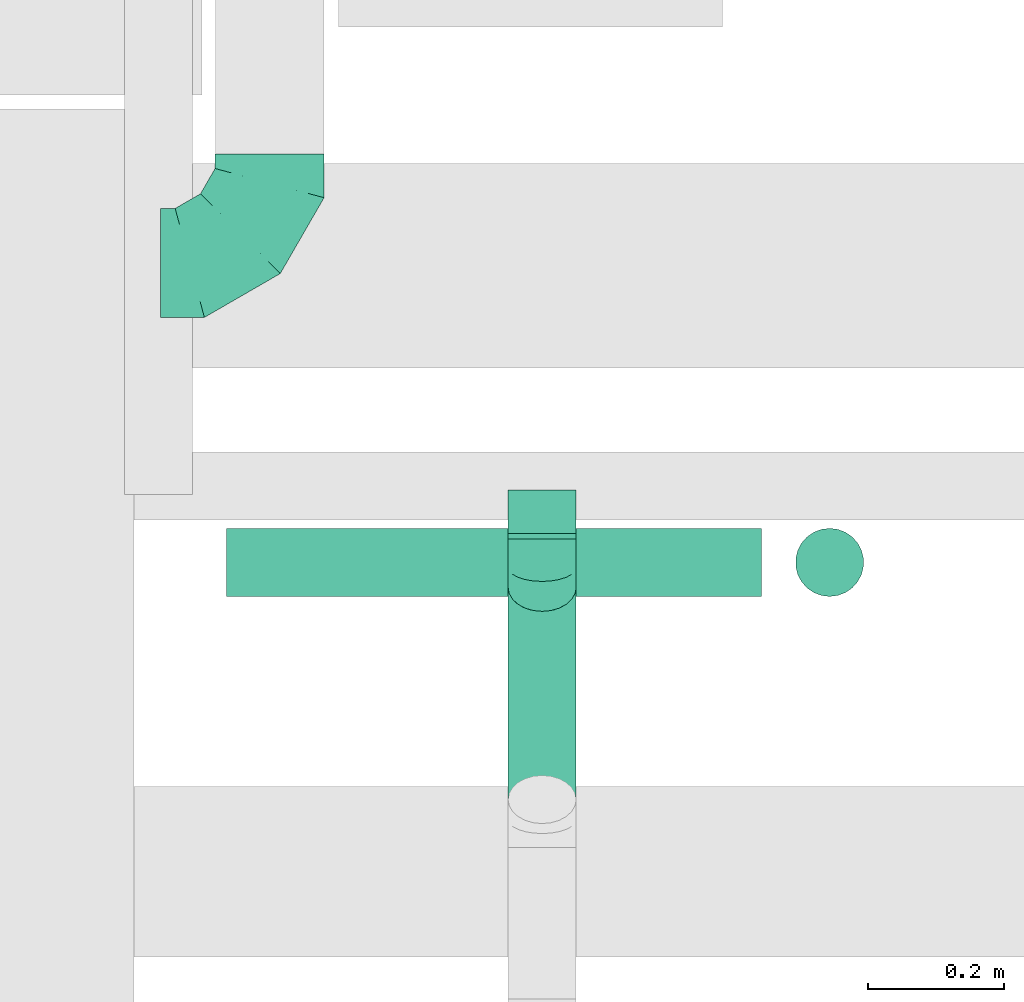
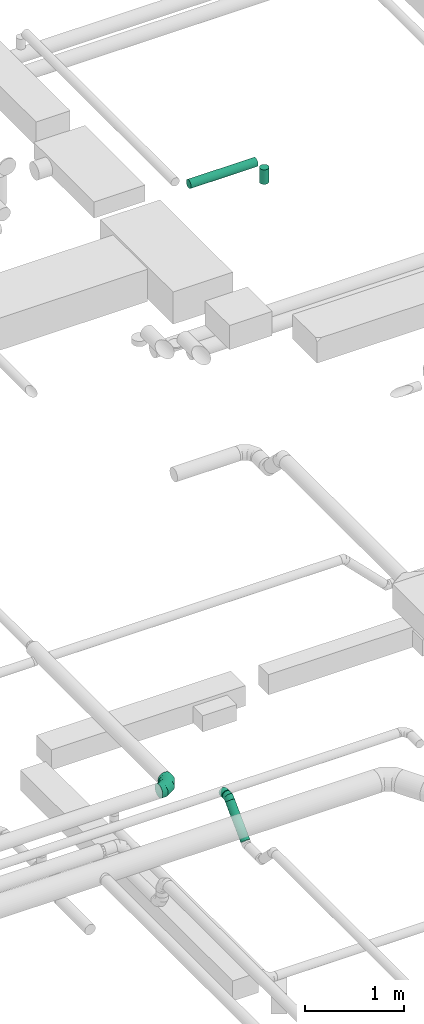
# One storey, part 111 of 337: 4 flow segments, 3 flow fittings.
"""IFC2X3 building model written with IfcOpenShell, lengths in millimetres."""

from ifc_helpers import new_model, entity, si_unit, converted_unit, derived_unit, direction, frame, origin, origin_2d_with_axis, place, context, subcontext, project, spatial, circle, extrude, faceted_brep, source, transform, mapped, material, type_object, type_shapes, element, save


model = new_model("IFC2X3")

# Units and contexts
model_context = context("Model", 3, precision=0.01, world=origin(), true_north=direction((6.12303176911189e-17, 1.0)))
body_context = subcontext(model_context, "Body", "Model", "MODEL_VIEW")
ifc_project = project(units=[si_unit("LENGTHUNIT", "METRE", prefix="MILLI"), si_unit("AREAUNIT", "SQUARE_METRE"), si_unit("VOLUMEUNIT", "CUBIC_METRE"), converted_unit("PLANEANGLEUNIT", "DEGREE", entity("IfcRatioMeasure", 0.0174532925199433), si_unit("PLANEANGLEUNIT", "RADIAN"), dimensions=[0, 0, 0, 0, 0, 0, 0]), si_unit("MASSUNIT", "GRAM", prefix="KILO"), derived_unit("MASSDENSITYUNIT", [(si_unit("MASSUNIT", "GRAM", prefix="KILO"), 1), (si_unit("LENGTHUNIT", "METRE"), -3)]), derived_unit("MOMENTOFINERTIAUNIT", [(si_unit("LENGTHUNIT", "METRE"), 4)]), si_unit("TIMEUNIT", "SECOND"), si_unit("FREQUENCYUNIT", "HERTZ"), si_unit("THERMODYNAMICTEMPERATUREUNIT", "DEGREE_CELSIUS"), derived_unit("THERMALTRANSMITTANCEUNIT", [(si_unit("MASSUNIT", "GRAM", prefix="KILO"), 1), (si_unit("THERMODYNAMICTEMPERATUREUNIT", "KELVIN"), -1), (si_unit("TIMEUNIT", "SECOND"), -3)]), derived_unit("VOLUMETRICFLOWRATEUNIT", [(si_unit("LENGTHUNIT", "METRE"), 3), (si_unit("TIMEUNIT", "SECOND"), -1)]), derived_unit("MASSFLOWRATEUNIT", [(si_unit("MASSUNIT", "GRAM", prefix="KILO"), 1), (si_unit("TIMEUNIT", "SECOND"), -1)]), derived_unit("ROTATIONALFREQUENCYUNIT", [(si_unit("TIMEUNIT", "SECOND"), -1)]), si_unit("ELECTRICCURRENTUNIT", "AMPERE"), si_unit("ELECTRICVOLTAGEUNIT", "VOLT"), si_unit("POWERUNIT", "WATT"), si_unit("FORCEUNIT", "NEWTON", prefix="KILO"), si_unit("ILLUMINANCEUNIT", "LUX"), si_unit("LUMINOUSFLUXUNIT", "LUMEN"), si_unit("LUMINOUSINTENSITYUNIT", "CANDELA"), derived_unit("USERDEFINED", [(si_unit("MASSUNIT", "GRAM", prefix="KILO"), -1), (si_unit("LENGTHUNIT", "METRE"), -2), (si_unit("TIMEUNIT", "SECOND"), 3), (si_unit("LUMINOUSFLUXUNIT", "LUMEN"), 1)]), derived_unit("LINEARVELOCITYUNIT", [(si_unit("LENGTHUNIT", "METRE"), 1), (si_unit("TIMEUNIT", "SECOND"), -1)]), si_unit("PRESSUREUNIT", "PASCAL"), derived_unit("USERDEFINED", [(si_unit("LENGTHUNIT", "METRE"), -2), (si_unit("MASSUNIT", "GRAM", prefix="KILO"), 1), (si_unit("TIMEUNIT", "SECOND"), -2)]), derived_unit("LINEARFORCEUNIT", [(si_unit("MASSUNIT", "GRAM", prefix="KILO"), 1), (si_unit("LENGTHUNIT", "METRE"), 1), (si_unit("TIMEUNIT", "SECOND"), -2), (si_unit("LENGTHUNIT", "METRE"), -1)]), derived_unit("PLANARFORCEUNIT", [(si_unit("MASSUNIT", "GRAM", prefix="KILO"), 1), (si_unit("LENGTHUNIT", "METRE"), 1), (si_unit("TIMEUNIT", "SECOND"), -2), (si_unit("LENGTHUNIT", "METRE"), -2)])], contexts=[model_context])

# Site, building, storey
site_placement = place(None, origin())
site = spatial("IfcSite", under=ifc_project, at=site_placement, CompositionType="ELEMENT")
building_placement = place(site_placement, origin())
building = spatial("IfcBuilding", under=site, at=building_placement, CompositionType="ELEMENT")
storey_placement = place(building_placement, origin())
storey = spatial("IfcBuildingStorey", under=building, at=storey_placement, CompositionType="ELEMENT", Elevation=0.0)

# Flow segments
duct_segment_type = type_object("IfcDuctSegmentType", PredefinedType="NOTDEFINED")
flow_segment_1_placement = place(storey_placement, frame((19653.1, 12232.52, 3598.4)))
element("IfcFlowSegment", 1, at=flow_segment_1_placement, inside=storey, type_object=duct_segment_type, context=body_context, shape_type="SweptSolid", body=[
    extrude(circle(Radius=50.0, at=origin_2d_with_axis()), frame((51.6, 0.0, 51.6), z_axis=(0.0, 1.0, 0.0), x_axis=(-1.0, 0.0, 0.0)), (0.0, 0.0, 1.0), 7.842712474644),
])
flow_segment_2_placement = place(storey_placement, frame((19653.1, 11813.43, 3272.34)))
element("IfcFlowSegment", 2, at=flow_segment_2_placement, inside=storey, type_object=duct_segment_type, context=body_context, shape_type="SweptSolid", body=[
    extrude(circle(Radius=50.0, at=origin_2d_with_axis()), frame((51.6, 36.95, 36.95), z_axis=(0.0, 0.707106781186546, 0.707106781186549), x_axis=(1.0, 0.0, 0.0)), (0.0, 0.0, 1.0), 440.416305603425),
])
flow_segment_3_placement = place(storey_placement, frame((19241.57, 12146.69, 11348.4)))
element("IfcFlowSegment", 3, at=flow_segment_3_placement, inside=storey, type_object=duct_segment_type, context=body_context, shape_type="SweptSolid", body=[
    extrude(circle(Radius=50.0, at=origin_2d_with_axis()), frame((0.0, 51.6, 51.6), z_axis=(1.0, 0.0, 0.0), x_axis=(0.0, -1.0, 0.0)), (0.0, 0.0, 1.0), 785.000000000036),
])
flow_segment_4_placement = place(storey_placement, frame((20074.97, 12146.69, 11120.0)))
element("IfcFlowSegment", 4, at=flow_segment_4_placement, inside=storey, type_object=duct_segment_type, context=body_context, shape_type="SweptSolid", body=[
    extrude(circle(Radius=50.0, at=origin_2d_with_axis()), frame((51.6, 51.6, 0.0), z_axis=(0.0, 0.0, 1.0), x_axis=(0.0, -1.0, 0.0)), (0.0, 0.0, 1.0), 180.000000000007),
])

# Flow fittings
ifc_material = material()
duct_fitting_type_1 = type_object("IfcDuctFittingType", PredefinedType="NOTDEFINED", material=ifc_material)
shared_shape_1 = source(origin(), body_context, "Body", "Brep", [
    faceted_brep([(-160.0, 0.0, -80.0), (-160.0, -20.71, -77.27), (-160.0, -40.0, -69.28), (-160.0, -56.57, -56.57), (-160.0, -69.28, -40.0), (-160.0, -77.27, -20.71), (-160.0, -80.0, 0.0), (-160.0, -77.27, 20.71), (-160.0, -69.28, 40.0), (-160.0, -56.57, 56.57), (-160.0, -40.0, 69.28), (-160.0, -20.71, 77.27), (-160.0, 0.0, 80.0), (-160.0, 20.71, 77.27), (-160.0, 40.0, 69.28), (-160.0, 56.57, 56.57), (-160.0, 69.28, 40.0), (-160.0, 77.27, 20.71), (-160.0, 80.0, 0.0), (-160.0, 77.27, -20.71), (-160.0, 69.28, -40.0), (-160.0, 56.57, -56.57), (-160.0, 40.0, -69.28), (-160.0, 20.71, -77.27), (-122.68, 20.71, 77.27), (-127.85, 40.0, 69.28), (-117.13, 0.0, 80.0), (-132.29, 56.57, 56.57), (-137.83, 77.27, 20.71), (-138.56, 80.0, 0.0), (-135.69, 69.28, 40.0), (-135.69, 69.28, -40.0), (-132.29, 56.57, -56.57), (-137.83, 77.27, -20.71), (-122.68, 20.71, -77.27), (-117.13, 0.0, -80.0), (-127.85, 40.0, -69.28), (-111.58, -20.71, -77.27), (-106.41, -40.0, -69.28), (-101.97, -56.57, -56.57), (-98.56, -69.28, -40.0), (-96.42, -77.27, -20.71), (-95.69, -80.0, 0.0), (-96.42, -77.27, 20.71), (-98.56, -69.28, 40.0), (-101.97, -56.57, 56.57), (-106.41, -40.0, 69.28), (-111.58, -20.71, 77.27), (-58.03, 58.03, 77.27), (-72.15, 72.15, 69.28), (-42.87, 42.87, 80.0), (-84.28, 84.28, 56.57), (-93.59, 93.59, 40.0), (-99.44, 99.44, 20.71), (-101.44, 101.44, 0.0), (-99.44, 99.44, -20.71), (-93.59, 93.59, -40.0), (-84.28, 84.28, -56.57), (-58.03, 58.03, -77.27), (-42.87, 42.87, -80.0), (-72.15, 72.15, -69.28), (-27.71, 27.71, -77.27), (-13.59, 13.59, -69.28), (-1.46, 1.46, -56.57), (7.85, -7.85, -40.0), (13.7, -13.7, -20.71), (15.69, -15.69, 0.0), (13.7, -13.7, 20.71), (7.85, -7.85, 40.0), (-1.46, 1.46, 56.57), (-13.59, 13.59, 69.28), (-27.71, 27.71, 77.27), (-20.71, 122.68, 77.27), (-40.0, 127.85, 69.28), (0.0, 117.13, 80.0), (-56.57, 132.29, 56.57), (-69.28, 135.69, 40.0), (-77.27, 137.83, 20.71), (-80.0, 138.56, 0.0), (-77.27, 137.83, -20.71), (-69.28, 135.69, -40.0), (-56.57, 132.29, -56.57), (-20.71, 122.68, -77.27), (0.0, 117.13, -80.0), (-40.0, 127.85, -69.28), (20.71, 111.58, -77.27), (40.0, 106.41, -69.28), (56.57, 101.97, -56.57), (69.28, 98.56, -40.0), (77.27, 96.42, -20.71), (80.0, 95.69, 0.0), (77.27, 96.42, 20.71), (69.28, 98.56, 40.0), (56.57, 101.97, 56.57), (40.0, 106.41, 69.28), (20.71, 111.58, 77.27), (-20.71, 160.0, -77.27), (-40.0, 160.0, -69.28), (-56.57, 160.0, -56.57), (-69.28, 160.0, -40.0), (-77.27, 160.0, -20.71), (-80.0, 160.0, 0.0), (-77.27, 160.0, 20.71), (-69.28, 160.0, 40.0), (-56.57, 160.0, 56.57), (-40.0, 160.0, 69.28), (-20.71, 160.0, 77.27), (0.0, 160.0, 80.0), (20.71, 160.0, 77.27), (40.0, 160.0, 69.28), (56.57, 160.0, 56.57), (69.28, 160.0, 40.0), (77.27, 160.0, 20.71), (80.0, 160.0, 0.0), (77.27, 160.0, -20.71), (69.28, 160.0, -40.0), (56.57, 160.0, -56.57), (40.0, 160.0, -69.28), (20.71, 160.0, -77.27), (0.0, 160.0, -80.0)], [[[0, 1, 2, 3, 4, 5, 6, 7, 8, 9, 10, 11, 12, 13, 14, 15, 16, 17, 18, 19, 20, 21, 22, 23]], [[24, 25, 14, 13]], [[26, 24, 13, 12]], [[14, 25, 27, 15]], [[28, 29, 18, 17]], [[30, 28, 17, 16]], [[15, 27, 30, 16]], [[20, 31, 32, 21]], [[33, 31, 20, 19]], [[18, 29, 33, 19]], [[34, 35, 0, 23]], [[36, 34, 23, 22]], [[32, 36, 22, 21]], [[1, 0, 35, 37]], [[2, 1, 37, 38]], [[3, 2, 38, 39]], [[5, 4, 40, 41]], [[6, 5, 41, 42]], [[39, 40, 4, 3]], [[6, 42, 43, 7]], [[7, 43, 44, 8]], [[8, 44, 45, 9]], [[9, 45, 46, 10]], [[10, 46, 47, 11]], [[26, 12, 11, 47]], [[48, 49, 25, 24]], [[50, 48, 24, 26]], [[27, 25, 49, 51]], [[52, 53, 28, 30]], [[51, 52, 30, 27]], [[29, 28, 53, 54]], [[55, 56, 31, 33]], [[54, 55, 33, 29]], [[32, 31, 56, 57]], [[58, 59, 35, 34]], [[60, 58, 34, 36]], [[57, 60, 36, 32]], [[37, 35, 59, 61]], [[38, 37, 61, 62]], [[39, 38, 62, 63]], [[41, 40, 64, 65]], [[42, 41, 65, 66]], [[63, 64, 40, 39]], [[43, 42, 66, 67]], [[44, 43, 67, 68]], [[68, 69, 45, 44]], [[46, 45, 69, 70]], [[47, 46, 70, 71]], [[26, 47, 71, 50]], [[72, 73, 49, 48]], [[74, 72, 48, 50]], [[51, 49, 73, 75]], [[76, 77, 53, 52]], [[75, 76, 52, 51]], [[54, 53, 77, 78]], [[79, 80, 56, 55]], [[78, 79, 55, 54]], [[57, 56, 80, 81]], [[82, 83, 59, 58]], [[84, 82, 58, 60]], [[81, 84, 60, 57]], [[61, 59, 83, 85]], [[62, 61, 85, 86]], [[63, 62, 86, 87]], [[65, 64, 88, 89]], [[66, 65, 89, 90]], [[87, 88, 64, 63]], [[67, 66, 90, 91]], [[68, 67, 91, 92]], [[92, 93, 69, 68]], [[70, 69, 93, 94]], [[71, 70, 94, 95]], [[50, 71, 95, 74]], [[96, 97, 98, 99, 100, 101, 102, 103, 104, 105, 106, 107, 108, 109, 110, 111, 112, 113, 114, 115, 116, 117, 118, 119]], [[72, 74, 107, 106]], [[73, 72, 106, 105]], [[75, 73, 105, 104]], [[77, 76, 103, 102]], [[78, 77, 102, 101]], [[75, 104, 103, 76]], [[78, 101, 100, 79]], [[79, 100, 99, 80]], [[80, 99, 98, 81]], [[84, 97, 96, 82]], [[82, 96, 119, 83]], [[84, 81, 98, 97]], [[118, 117, 86, 85]], [[119, 118, 85, 83]], [[116, 87, 86, 117]], [[88, 115, 114, 89]], [[89, 114, 113, 90]], [[115, 88, 87, 116]], [[112, 111, 92, 91]], [[113, 112, 91, 90]], [[111, 110, 93, 92]], [[95, 94, 109, 108]], [[74, 95, 108, 107]], [[110, 109, 94, 93]]]),
])
type_shapes(duct_fitting_type_1, [shared_shape_1])
flow_fitting_1_placement = place(storey_placement, frame((19304.69, 12637.83, 3650.0)))
element("IfcFlowFitting", 5, at=flow_fitting_1_placement, inside=storey, type_object=duct_fitting_type_1, material=ifc_material, context=body_context, shape_type="MappedRepresentation", body=[
    mapped(shared_shape_1, transform((0.0, 0.0, 0.0), scale=1.0)),
])
duct_fitting_type_2 = type_object("IfcDuctFittingType", PredefinedType="NOTDEFINED", material=ifc_material)
shared_shape_2 = source(origin(), body_context, "Body", "Brep", [
    faceted_brep([(-41.42, 0.0, -50.0), (-41.42, -12.94, -48.3), (-41.42, -25.0, -43.3), (-41.42, -35.36, -35.36), (-41.42, -43.3, -25.0), (-41.42, -48.3, -12.94), (-41.42, -50.0, 0.0), (-41.42, -48.3, 12.94), (-41.42, -43.3, 25.0), (-41.42, -35.36, 35.36), (-41.42, -25.0, 43.3), (-41.42, -12.94, 48.3), (-41.42, 0.0, 50.0), (-41.42, 12.94, 48.3), (-41.42, 25.0, 43.3), (-41.42, 35.36, 35.36), (-41.42, 43.3, 25.0), (-41.42, 48.3, 12.94), (-41.42, 50.0, 0.0), (-41.42, 48.3, -12.94), (-41.42, 43.3, -25.0), (-41.42, 35.36, -35.36), (-41.42, 25.0, -43.3), (-41.42, 12.94, -48.3), (-5.36, 12.94, 48.3), (-10.36, 25.0, 43.3), (0.0, 0.0, 50.0), (-14.64, 35.36, 35.36), (-20.0, 48.3, 12.94), (-20.71, 50.0, 0.0), (-17.94, 43.3, 25.0), (-17.94, 43.3, -25.0), (-14.64, 35.36, -35.36), (-20.0, 48.3, -12.94), (-5.36, 12.94, -48.3), (0.0, 0.0, -50.0), (-10.36, 25.0, -43.3), (5.36, -12.94, -48.3), (10.36, -25.0, -43.3), (14.64, -35.36, -35.36), (17.94, -43.3, -25.0), (20.0, -48.3, -12.94), (20.71, -50.0, 0.0), (20.0, -48.3, 12.94), (17.94, -43.3, 25.0), (14.64, -35.36, 35.36), (10.36, -25.0, 43.3), (5.36, -12.94, 48.3), (29.29, 29.29, 50.0), (20.14, 38.44, 48.3), (11.61, 46.97, 43.3), (4.29, 54.29, 35.36), (-1.33, 59.91, 25.0), (-4.86, 63.44, 12.94), (-6.07, 64.64, 0.0), (-4.86, 63.44, -12.94), (-1.33, 59.91, -25.0), (4.29, 54.29, -35.36), (11.61, 46.97, -43.3), (20.14, 38.44, -48.3), (29.29, 29.29, -50.0), (38.44, 20.14, -48.3), (46.97, 11.61, -43.3), (54.29, 4.29, -35.36), (59.91, -1.33, -25.0), (63.44, -4.86, -12.94), (64.64, -6.07, 0.0), (63.44, -4.86, 12.94), (59.91, -1.33, 25.0), (54.29, 4.29, 35.36), (46.97, 11.61, 43.3), (38.44, 20.14, 48.3)], [[[0, 1, 2, 3, 4, 5, 6, 7, 8, 9, 10, 11, 12, 13, 14, 15, 16, 17, 18, 19, 20, 21, 22, 23]], [[24, 25, 14, 13]], [[26, 24, 13, 12]], [[14, 25, 27, 15]], [[28, 29, 18, 17]], [[30, 28, 17, 16]], [[16, 15, 27, 30]], [[20, 31, 32, 21]], [[33, 31, 20, 19]], [[18, 29, 33, 19]], [[34, 35, 0, 23]], [[36, 34, 23, 22]], [[32, 36, 22, 21]], [[1, 0, 35, 37]], [[2, 1, 37, 38]], [[38, 39, 3, 2]], [[5, 4, 40, 41]], [[6, 5, 41, 42]], [[39, 40, 4, 3]], [[6, 42, 43, 7]], [[7, 43, 44, 8]], [[8, 44, 45, 9]], [[9, 45, 46, 10]], [[10, 46, 47, 11]], [[26, 12, 11, 47]], [[24, 26, 48, 49]], [[25, 24, 49, 50]], [[27, 25, 50, 51]], [[28, 30, 52, 53]], [[29, 28, 53, 54]], [[27, 51, 52, 30]], [[29, 54, 55, 33]], [[33, 55, 56, 31]], [[31, 56, 57, 32]], [[36, 58, 59, 34]], [[34, 59, 60, 35]], [[36, 32, 57, 58]], [[61, 62, 38, 37]], [[60, 61, 37, 35]], [[63, 39, 38, 62]], [[40, 64, 65, 41]], [[41, 65, 66, 42]], [[64, 40, 39, 63]], [[43, 42, 66, 67]], [[44, 43, 67, 68]], [[68, 69, 45, 44]], [[47, 46, 70, 71]], [[26, 47, 71, 48]], [[69, 70, 46, 45]], [[59, 58, 57, 56, 55, 54, 53, 52, 51, 50, 49, 48, 71, 70, 69, 68, 67, 66, 65, 64, 63, 62, 61, 60]]]),
])
type_shapes(duct_fitting_type_2, [shared_shape_2])
flow_fitting_2_placement = place(storey_placement, frame((19704.69, 12191.09, 3650.0), z_axis=(1.0, 0.0, 0.0), x_axis=(0.0, -1.0, 0.0)))
element("IfcFlowFitting", 6, at=flow_fitting_2_placement, inside=storey, type_object=duct_fitting_type_2, material=ifc_material, context=body_context, shape_type="MappedRepresentation", body=[
    mapped(shared_shape_2, transform((0.0, 0.0, 0.0), scale=1.0)),
])
duct_fitting_type_3 = type_object("IfcDuctFittingType", PredefinedType="NOTDEFINED", material=ifc_material)
shared_shape_3 = source(origin(), body_context, "Body", "Brep", [
    faceted_brep([(20.0, 12.94, -48.3), (20.0, 25.0, -43.3), (20.0, 35.36, -35.36), (20.0, 43.3, -25.0), (20.0, 48.3, -12.94), (20.0, 50.0, 0.0), (20.0, 48.3, 12.94), (20.0, 43.3, 25.0), (20.0, 35.36, 35.36), (20.0, 25.0, 43.3), (20.0, 12.94, 48.3), (20.0, 0.0, 50.0), (20.0, -12.94, 48.3), (20.0, -25.0, 43.3), (20.0, -35.36, 35.36), (20.0, -43.3, 25.0), (20.0, -48.3, 12.94), (20.0, -50.0, 0.0), (20.0, -48.3, -12.94), (20.0, -43.3, -25.0), (20.0, -35.36, -35.36), (20.0, -25.0, -43.3), (20.0, -12.94, -48.3), (20.0, 0.0, -50.0), (0.0, 0.0, 50.0), (0.0, 12.94, 48.3), (-43.9, 12.94, 48.3), (-43.9, 0.0, 50.0), (0.0, 25.0, 43.3), (-43.9, 25.0, 43.3), (0.0, 35.36, 35.36), (-43.9, 35.36, 35.36), (0.0, 43.3, 25.0), (0.0, 48.3, 12.94), (-43.9, 48.3, 12.94), (-43.9, 43.3, 25.0), (0.0, 50.0, 0.0), (-43.9, 50.0, 0.0), (0.0, 48.3, -12.94), (-43.9, 48.3, -12.94), (0.0, 43.3, -25.0), (-43.9, 43.3, -25.0), (0.0, 35.36, -35.36), (-43.9, 35.36, -35.36), (0.0, 25.0, -43.3), (0.0, 12.94, -48.3), (-43.9, 12.94, -48.3), (-43.9, 25.0, -43.3), (0.0, 0.0, -50.0), (-43.9, 0.0, -50.0), (0.0, -12.94, -48.3), (-43.9, -12.94, -48.3), (0.0, -25.0, -43.3), (-43.9, -25.0, -43.3), (0.0, -35.36, -35.36), (-43.9, -35.36, -35.36), (0.0, -43.3, -25.0), (0.0, -48.3, -12.94), (-43.9, -48.3, -12.94), (-43.9, -43.3, -25.0), (0.0, -50.0, 0.0), (-43.9, -50.0, 0.0), (0.0, -48.3, 12.94), (-43.9, -48.3, 12.94), (0.0, -43.3, 25.0), (-43.9, -43.3, 25.0), (0.0, -35.36, 35.36), (-43.9, -35.36, 35.36), (0.0, -25.0, 43.3), (0.0, -12.94, 48.3), (-43.9, -12.94, 48.3), (-43.9, -25.0, 43.3)], [[[0, 1, 2, 3, 4, 5, 6, 7, 8, 9, 10, 11, 12, 13, 14, 15, 16, 17, 18, 19, 20, 21, 22, 23]], [[24, 11, 10, 25, 26, 27]], [[25, 10, 9, 28, 29, 26]], [[28, 9, 8, 30, 31, 29]], [[32, 7, 6, 33, 34, 35]], [[33, 6, 5, 36, 37, 34]], [[30, 8, 7, 32, 35, 31]], [[36, 5, 4, 38, 39, 37]], [[38, 4, 3, 40, 41, 39]], [[40, 3, 2, 42, 43, 41]], [[44, 1, 0, 45, 46, 47]], [[45, 0, 23, 48, 49, 46]], [[42, 2, 1, 44, 47, 43]], [[48, 23, 22, 50, 51, 49]], [[50, 22, 21, 52, 53, 51]], [[52, 21, 20, 54, 55, 53]], [[56, 19, 18, 57, 58, 59]], [[57, 18, 17, 60, 61, 58]], [[54, 20, 19, 56, 59, 55]], [[60, 17, 16, 62, 63, 61]], [[62, 16, 15, 64, 65, 63]], [[64, 15, 14, 66, 67, 65]], [[68, 13, 12, 69, 70, 71]], [[69, 12, 11, 24, 27, 70]], [[66, 14, 13, 68, 71, 67]], [[49, 51, 53, 55, 59, 58, 61, 63, 65, 67, 71, 70, 27, 26, 29, 31, 35, 34, 37, 39, 41, 43, 47, 46]]]),
])
type_shapes(duct_fitting_type_3, [shared_shape_3])
flow_fitting_3_placement = place(storey_placement, frame((19704.69, 12260.36, 3650.0), z_axis=(0.0, 0.0, -1.0), x_axis=(0.0, -1.0, 0.0)))
element("IfcFlowFitting", 7, at=flow_fitting_3_placement, inside=storey, type_object=duct_fitting_type_3, material=ifc_material, context=body_context, shape_type="MappedRepresentation", body=[
    mapped(shared_shape_3, transform((0.0, 0.0, 0.0), scale=1.0)),
])

save(model, "model.ifc")
